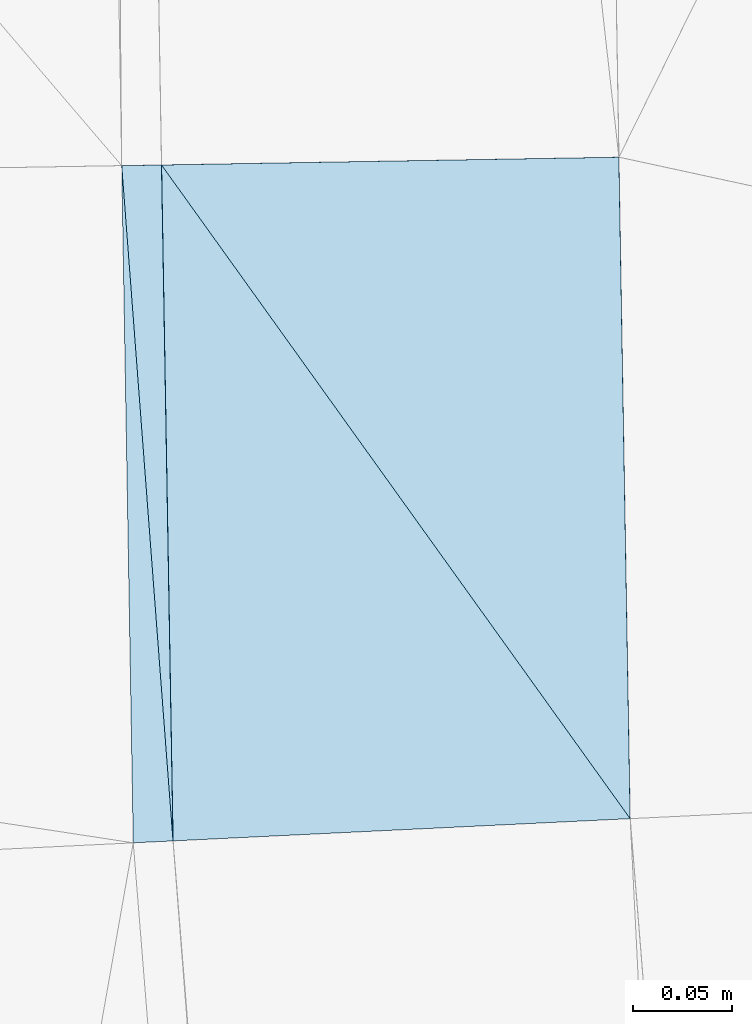
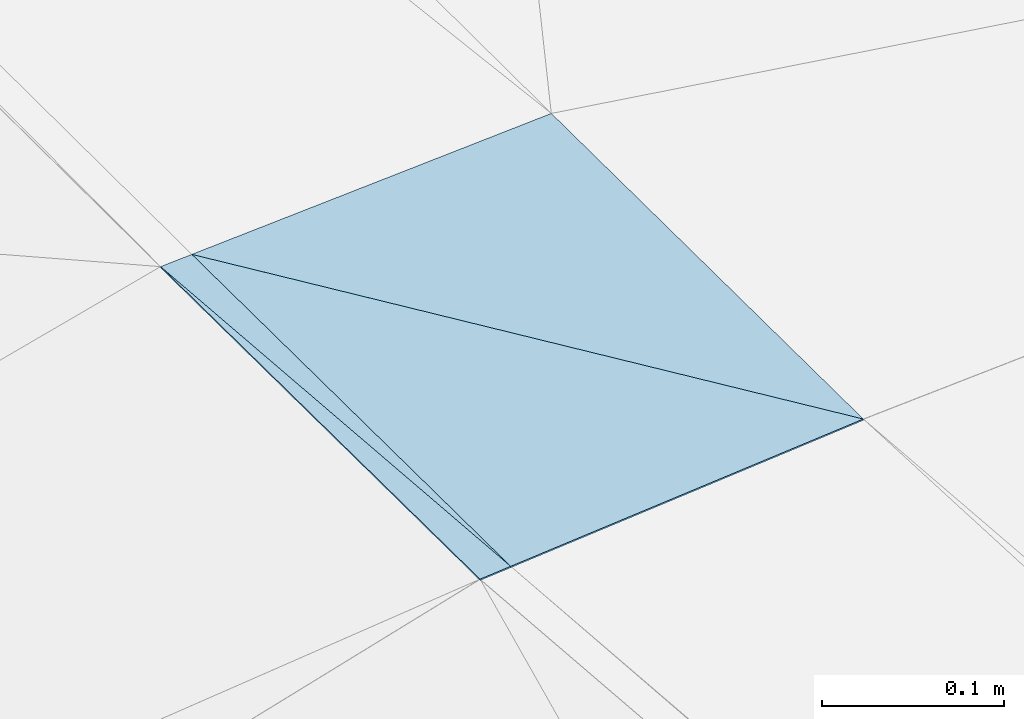
# One storey, part 165 of 275: 4 plates.
"""IFC2X3 building model written with IfcOpenShell, lengths in millimetres."""

from ifc_helpers import new_model, si_unit, frame, origin_with_axes, place, context, subcontext, project, spatial, polyline, outline, extrude, material, type_object, element, save


model = new_model("IFC2X3")

# Units and contexts
model_context = context("Model", 3, precision=1e-05, world=origin_with_axes())
body_context = subcontext(model_context, "Body", "Model", "MODEL_VIEW")
ifc_project = project(units=[si_unit("LENGTHUNIT", "METRE", prefix="MILLI"), si_unit("AREAUNIT", "SQUARE_METRE"), si_unit("VOLUMEUNIT", "CUBIC_METRE"), si_unit("MASSUNIT", "GRAM", prefix="KILO"), si_unit("TIMEUNIT", "SECOND"), si_unit("PLANEANGLEUNIT", "RADIAN"), si_unit("SOLIDANGLEUNIT", "STERADIAN"), si_unit("THERMODYNAMICTEMPERATUREUNIT", "DEGREE_CELSIUS"), si_unit("LUMINOUSINTENSITYUNIT", "LUMEN")], contexts=[model_context])

# Site, building, storey
site_placement = place(None, origin_with_axes())
site = spatial("IfcSite", under=ifc_project, at=site_placement, CompositionType="ELEMENT")
building_placement = place(site_placement, origin_with_axes())
building = spatial("IfcBuilding", under=site, at=building_placement, Name="Undefined", CompositionType="ELEMENT")
storey_placement = place(building_placement, origin_with_axes())
storey = spatial("IfcBuildingStorey", under=building, at=storey_placement, Name="Undefined", CompositionType="ELEMENT", Elevation=0.0)

# Plates
ifc_material = material()
plate_type_1 = type_object("IfcPlateType", PredefinedType="NOTDEFINED")
plate_1_placement = place(storey_placement, frame((-94773.6218309965, -19474.7963012178, 40548.1486704569), z_axis=(0.0496819107747987, 0.0151548379296849, -0.998650108210624), x_axis=(0.998608221867496, 0.0169671560478416, 0.0499373090412924)))
element("IfcPlate", 1, at=plate_1_placement, inside=storey, type_object=plate_type_1, material=ifc_material, Name="00_PR", context=body_context, shape_type="SweptSolid", body=[
    extrude(outline(polyline([(0.0, 0.0), (20.0250701904297, 1.0550138540566e-10), (19.8026123046875, 339.931579589844), (0.0, 0.0)])), frame((-8.85201319254618e-08, 2.18876761149539e-07, -0.5000001331573), z_axis=(0.0, 0.0, 1.0), x_axis=(1.0, 0.0, 0.0)), (0.0, 0.0, 1.0), 1.0),
])
plate_2_placement = place(storey_placement, frame((-94747.8300807456, -19814.3039442433, 40544.279648239), z_axis=(0.0487850041122555, 0.0150872162377967, -0.99869534858232), x_axis=(-0.997593448085969, -0.0485850940518407, -0.049465149063979)))
element("IfcPlate", 2, at=plate_2_placement, inside=storey, type_object=plate_type_1, material=ifc_material, Name="00_PR", context=body_context, shape_type="SweptSolid", body=[
    extrude(outline(polyline([(0.0, 0.0), (20.0343074798584, -1.25510268844664e-10), (9.04373645782471, 340.387756347656), (0.0, 0.0)])), frame((-8.85201319254618e-08, 2.18876761149539e-07, -0.5000001331573), z_axis=(0.0, 0.0, 1.0), x_axis=(1.0, 0.0, 0.0)), (0.0, 0.0, 1.0), 1.0),
])
plate_type_2 = type_object("IfcPlateType", PredefinedType="NOTDEFINED")
plate_3_placement = place(storey_placement, frame((-94753.6245990498, -19474.4562201561, 40549.1486752212), z_axis=(0.0496707045492066, 0.0157799318341029, -0.998640983968161), x_axis=(0.998607579908415, 0.0170036750400217, 0.0499377250642457)))
element("IfcPlate", 3, at=plate_3_placement, inside=storey, type_object=plate_type_2, material=ifc_material, Name="00_PR", context=body_context, shape_type="SweptSolid", body=[
    extrude(outline(polyline([(0.0, 0.0), (230.286819458008, -2.61934474110603e-10), (230.047698974609, 332.658325195313), (0.0, 0.0)])), frame((-8.85201319254618e-08, 2.18876761149539e-07, -0.5000001331573), z_axis=(0.0, 0.0, 1.0), x_axis=(1.0, 0.0, 0.0)), (0.0, 0.0, 1.0), 1.0),
])
plate_type_3 = type_object("IfcPlateType", PredefinedType="NOTDEFINED")
plate_4_placement = place(storey_placement, frame((-94517.9868089972, -19803.1136975152, 40555.6756481793), z_axis=(0.0487797823787252, 0.0151400959099161, -0.998694803394372), x_axis=(-0.997594362239565, -0.0485691850539613, -0.0494623360854378)))
element("IfcPlate", 4, at=plate_4_placement, inside=storey, type_object=plate_type_3, material=ifc_material, Name="00_PR", context=body_context, shape_type="SweptSolid", body=[
    extrude(outline(polyline([(0.0, 0.0), (230.397521972656, 3.23780113831162e-10), (219.431610107422, 339.754730224609), (0.0, 0.0)])), frame((-8.85201319254618e-08, 2.18876761149539e-07, -0.5000001331573), z_axis=(0.0, 0.0, 1.0), x_axis=(1.0, 0.0, 0.0)), (0.0, 0.0, 1.0), 1.0),
])

save(model, "model.ifc")
